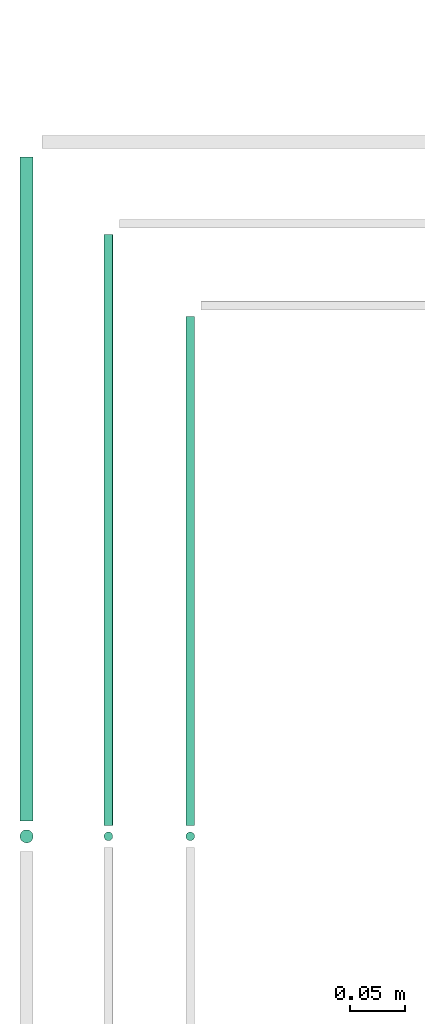
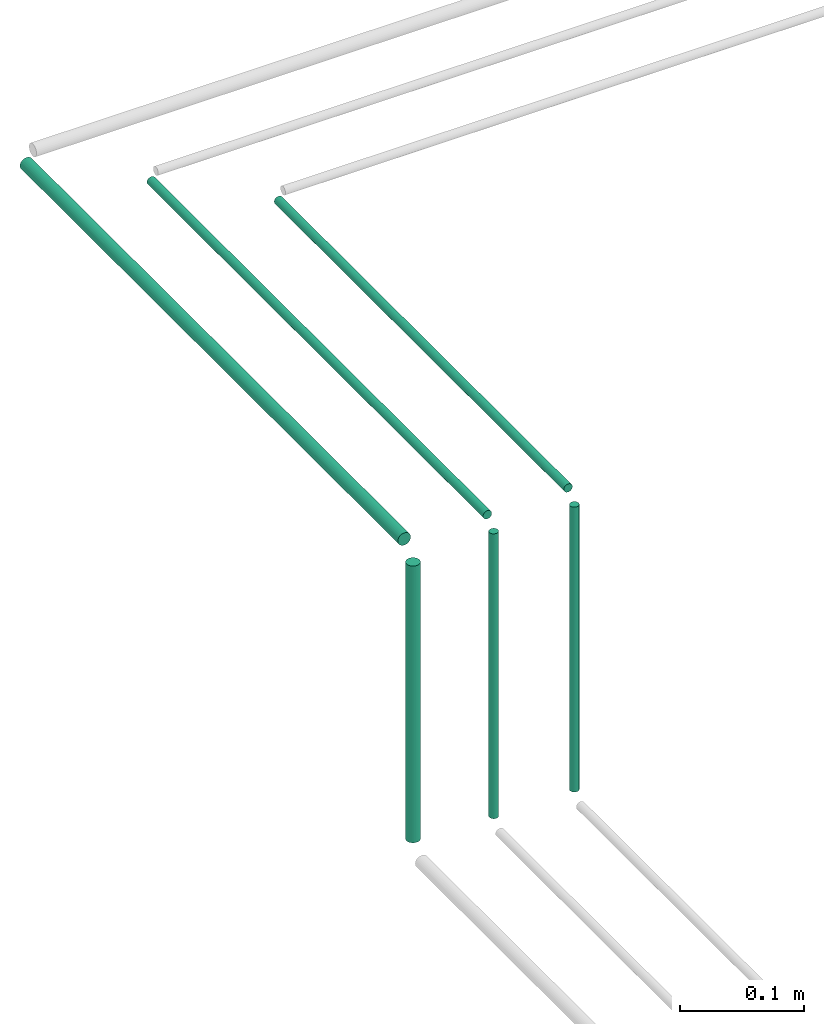
# One storey, part 28 of 65: 6 flow segments.
"""IFC2X3 building model written with IfcOpenShell, lengths in millimetres."""

from ifc_helpers import new_model, entity, si_unit, converted_unit, derived_unit, direction, frame, frame_2d, origin, origin_2d_with_axis, place, context, subcontext, project, spatial, circle, extrude, type_object, element, save


model = new_model("IFC2X3")

# Units and contexts
model_context = context("Model", 3, precision=0.01, world=origin(), true_north=direction((6.12303176911189e-17, 1.0)))
body_context = subcontext(model_context, "Body", "Model", "MODEL_VIEW")
ifc_project = project(units=[si_unit("LENGTHUNIT", "METRE", prefix="MILLI"), si_unit("AREAUNIT", "SQUARE_METRE"), si_unit("VOLUMEUNIT", "CUBIC_METRE"), converted_unit("PLANEANGLEUNIT", "DEGREE", entity("IfcRatioMeasure", 0.0174532925199433), si_unit("PLANEANGLEUNIT", "RADIAN"), dimensions=[0, 0, 0, 0, 0, 0, 0]), si_unit("MASSUNIT", "GRAM", prefix="KILO"), derived_unit("MASSDENSITYUNIT", [(si_unit("MASSUNIT", "GRAM", prefix="KILO"), 1), (si_unit("LENGTHUNIT", "METRE"), -3)]), derived_unit("MOMENTOFINERTIAUNIT", [(si_unit("LENGTHUNIT", "METRE"), 4)]), si_unit("TIMEUNIT", "SECOND"), si_unit("FREQUENCYUNIT", "HERTZ"), si_unit("THERMODYNAMICTEMPERATUREUNIT", "DEGREE_CELSIUS"), derived_unit("THERMALTRANSMITTANCEUNIT", [(si_unit("MASSUNIT", "GRAM", prefix="KILO"), 1), (si_unit("THERMODYNAMICTEMPERATUREUNIT", "KELVIN"), -1), (si_unit("TIMEUNIT", "SECOND"), -3)]), derived_unit("VOLUMETRICFLOWRATEUNIT", [(si_unit("LENGTHUNIT", "METRE"), 3), (si_unit("TIMEUNIT", "SECOND"), -1)]), derived_unit("MASSFLOWRATEUNIT", [(si_unit("MASSUNIT", "GRAM", prefix="KILO"), 1), (si_unit("TIMEUNIT", "SECOND"), -1)]), derived_unit("ROTATIONALFREQUENCYUNIT", [(si_unit("TIMEUNIT", "SECOND"), -1)]), si_unit("ELECTRICCURRENTUNIT", "AMPERE"), si_unit("ELECTRICVOLTAGEUNIT", "VOLT"), si_unit("POWERUNIT", "WATT"), si_unit("FORCEUNIT", "NEWTON", prefix="KILO"), si_unit("ILLUMINANCEUNIT", "LUX"), si_unit("LUMINOUSFLUXUNIT", "LUMEN"), si_unit("LUMINOUSINTENSITYUNIT", "CANDELA"), derived_unit("USERDEFINED", [(si_unit("MASSUNIT", "GRAM", prefix="KILO"), -1), (si_unit("LENGTHUNIT", "METRE"), -2), (si_unit("TIMEUNIT", "SECOND"), 3), (si_unit("LUMINOUSFLUXUNIT", "LUMEN"), 1)]), derived_unit("LINEARVELOCITYUNIT", [(si_unit("LENGTHUNIT", "METRE"), 1), (si_unit("TIMEUNIT", "SECOND"), -1)]), si_unit("PRESSUREUNIT", "PASCAL"), derived_unit("USERDEFINED", [(si_unit("LENGTHUNIT", "METRE"), -2), (si_unit("MASSUNIT", "GRAM", prefix="KILO"), 1), (si_unit("TIMEUNIT", "SECOND"), -2)]), derived_unit("LINEARFORCEUNIT", [(si_unit("MASSUNIT", "GRAM", prefix="KILO"), 1), (si_unit("LENGTHUNIT", "METRE"), 1), (si_unit("TIMEUNIT", "SECOND"), -2), (si_unit("LENGTHUNIT", "METRE"), -1)]), derived_unit("PLANARFORCEUNIT", [(si_unit("MASSUNIT", "GRAM", prefix="KILO"), 1), (si_unit("LENGTHUNIT", "METRE"), 1), (si_unit("TIMEUNIT", "SECOND"), -2), (si_unit("LENGTHUNIT", "METRE"), -2)])], contexts=[model_context])

# Site, building, storey
site_placement = place(None, frame((0.0, -0.00077364408347762, 0.0)))
site = spatial("IfcSite", under=ifc_project, at=site_placement, CompositionType="ELEMENT")
building_placement = place(site_placement, origin())
building = spatial("IfcBuilding", under=site, at=building_placement, CompositionType="ELEMENT")
storey_placement = place(building_placement, frame((0.0, 0.0, 19800.0)))
storey = spatial("IfcBuildingStorey", under=building, at=storey_placement, CompositionType="ELEMENT", Elevation=19800.0)

# Flow segments
pipe_segment_type = type_object("IfcPipeSegmentType", PredefinedType="NOTDEFINED")
flow_segment_1_placement = place(storey_placement, frame((16399.4047325915, 10388.7519198777, 2844.40472776409)))
element("IfcFlowSegment", 1, at=flow_segment_1_placement, inside=storey, type_object=pipe_segment_type, context=body_context, shape_type="SweptSolid", body=[
    extrude(circle(Radius=4.0, at=origin_2d_with_axis()), frame((5.59527223591499, 0.0, 5.59527223591499), z_axis=(0.0, 1.0, 0.0), x_axis=(-1.0, 0.0, 0.0)), (0.0, 0.0, 1.0), 541.37784411239),
])
flow_segment_2_placement = place(storey_placement, frame((16474.4047325923, 10388.7519198777, 2844.40472776409)))
element("IfcFlowSegment", 2, at=flow_segment_2_placement, inside=storey, type_object=pipe_segment_type, context=body_context, shape_type="SweptSolid", body=[
    extrude(circle(Radius=4.0, at=origin_2d_with_axis()), frame((5.59527223591499, 0.0, 5.59527223591499), z_axis=(0.0, 1.0, 0.0), x_axis=(-1.0, 0.0, 0.0)), (0.0, 0.0, 1.0), 466.37784411239),
])
flow_segment_3_placement = place(storey_placement, frame((16399.4047325915, 10373.1566476418, 2560.0)))
element("IfcFlowSegment", 3, at=flow_segment_3_placement, inside=storey, type_object=pipe_segment_type, context=body_context, shape_type="SweptSolid", body=[
    extrude(circle(Radius=4.0, at=origin_2d_with_axis()), frame((5.59527223591499, 5.59527223591499, 0.0)), (0.0, 0.0, 1.0), 279.999999999988),
])
flow_segment_4_placement = place(storey_placement, frame((16322.4047325917, 10371.1566476418, 2564.0)))
element("IfcFlowSegment", 4, at=flow_segment_4_placement, inside=storey, type_object=pipe_segment_type, context=body_context, shape_type="SweptSolid", body=[
    extrude(circle(Radius=6.0, at=frame_2d((-2.16573425859679e-12, 0.0), x_axis=(1.0, 0.0))), frame((7.59527223591887, 7.5952722359167, 0.0)), (0.0, 0.0, 1.0), 271.999999999994),
])
flow_segment_5_placement = place(storey_placement, frame((16322.4047325917, 10392.7519198777, 2842.40472776409)))
element("IfcFlowSegment", 5, at=flow_segment_5_placement, inside=storey, type_object=pipe_segment_type, context=body_context, shape_type="SweptSolid", body=[
    extrude(circle(Radius=6.0, at=origin_2d_with_axis()), frame((7.5952722359167, 0.0, 7.59527223591454), z_axis=(0.0, 1.0, 0.0), x_axis=(-1.0, 0.0, 0.0)), (0.0, 0.0, 1.0), 608.377844112388),
])
flow_segment_6_placement = place(storey_placement, frame((16474.4047325923, 10373.1566476418, 2560.0)))
element("IfcFlowSegment", 6, at=flow_segment_6_placement, inside=storey, type_object=pipe_segment_type, context=body_context, shape_type="SweptSolid", body=[
    extrude(circle(Radius=4.0, at=origin_2d_with_axis()), frame((5.59527223591499, 5.59527223591499, 0.0)), (0.0, 0.0, 1.0), 279.999999999984),
])

save(model, "model.ifc")
